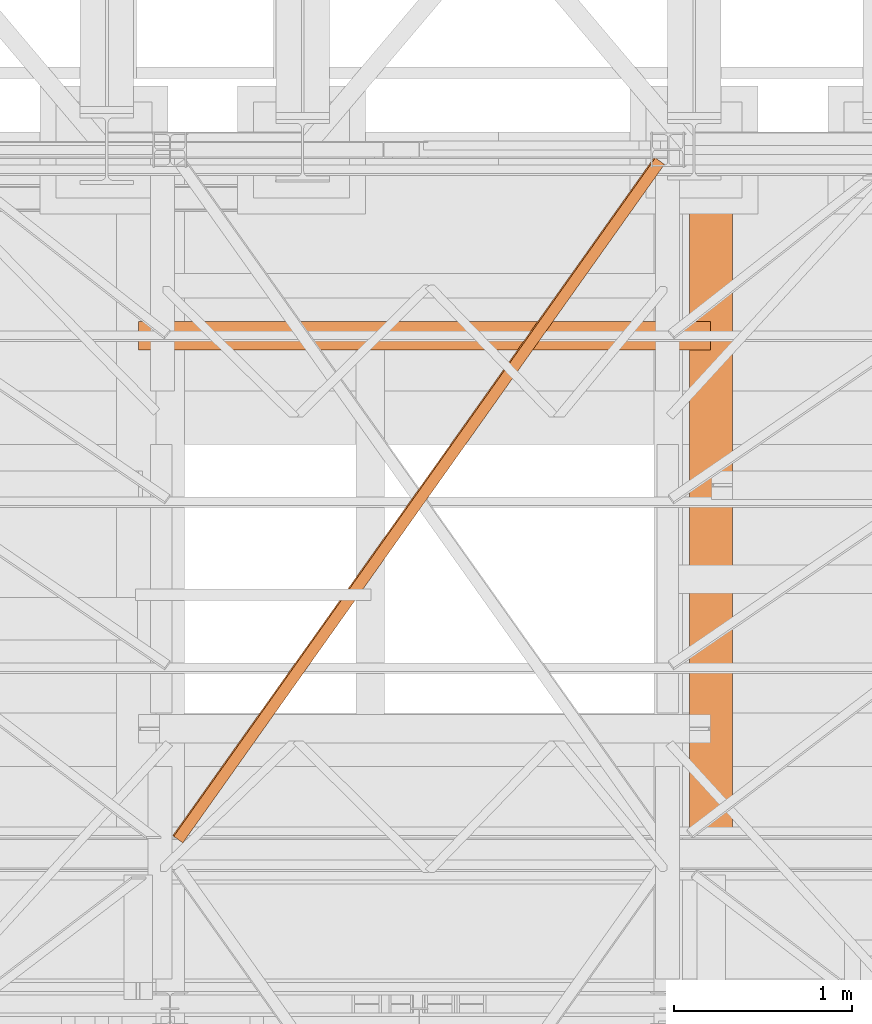
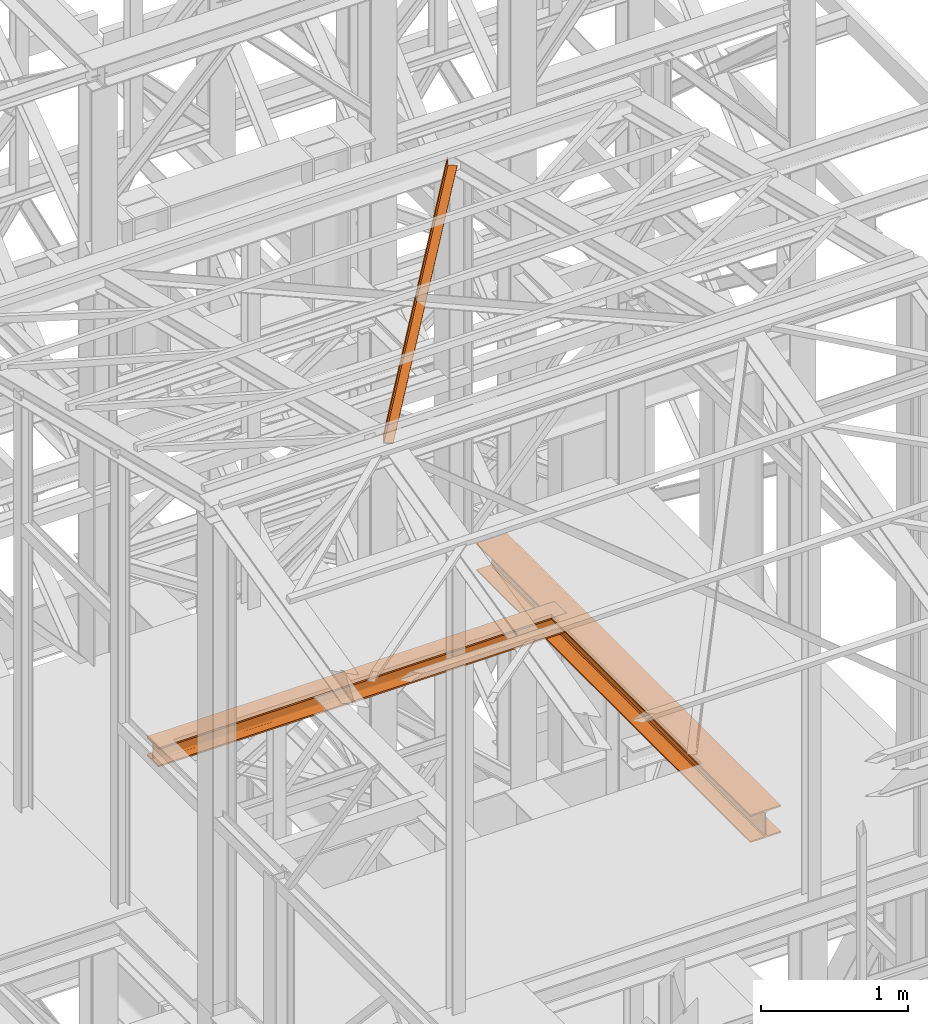
# One storey, part 69 of 208: 3 proxies.
"""IFC2X3 building model written with IfcOpenShell, lengths in millimetres."""

from ifc_helpers import new_model, entity, si_unit, converted_unit, frame, origin, origin_with_axes, place, context, subcontext, project, spatial, faceted_brep, element, save


model = new_model("IFC2X3")

# Units and contexts
model_context = context("Model", 3, precision=1e-05, world=origin())
plan_context = context("Plan", 3, precision=1e-05, world=origin())
body_context = subcontext(model_context, "Body", "Model", "MODEL_VIEW")
ifc_project = project(units=[si_unit("LENGTHUNIT", "METRE", prefix="MILLI"), converted_unit("PLANEANGLEUNIT", "DEGREE", entity("IfcPlaneAngleMeasure", 0.0174532925199433), si_unit("PLANEANGLEUNIT", "RADIAN"), dimensions=[0, 0, 0, 0, 0, 0, 0]), si_unit("AREAUNIT", "SQUARE_METRE"), si_unit("VOLUMEUNIT", "CUBIC_METRE")], contexts=[model_context, plan_context])

# Building, storey
building_placement = place(None, origin())
building = spatial("IfcBuilding", under=ifc_project, at=building_placement, CompositionType="COMPLEX")
storey_placement = place(building_placement, origin_with_axes())
storey = spatial("IfcBuildingStorey", under=building, at=storey_placement, Name="Geschoss", CompositionType="ELEMENT")

# Proxies
proxy_1_placement = place(storey_placement, frame((2372.004968677679, -18386.85030876191, 8324.990002086157), z_axis=(0.0, 0.0, 1.0), x_axis=(1.0, 0.0, 0.0)))
element("IfcBuildingElementProxy", 1, at=proxy_1_placement, inside=storey, Name="3D Element", context=body_context, shape_type="Brep", body=[
    faceted_brep([(3212.509999701976, 160.0099999999984, 0.01000000000021828), (3212.509999701976, 0.00999999999839929, 0.01000000000021828), (3212.509999701976, 0.00999999999839929, 13.01000000000022), (3212.509999701976, 61.0099999999984, 13.01000000000022), (3212.509999701976, 64.89227265598674, 13.52115656249407), (3212.509999701976, 68.50997812474452, 15.0196592323282), (3212.509999701976, 71.61660171780022, 17.40339828220203), (3212.509999701976, 74.00034076767406, 20.5100218752541), (3212.509999701976, 75.49884343750455, 24.12772734401187), (3212.509999701976, 76.0099999999984, 28.01000000000022), (3212.509999701976, 76.0099999999984, 132.0100000000002), (3212.509999701976, 75.49884343750455, 135.8922726559849), (3212.509999701976, 72.80847124273714, 141.0632899212706), (3212.509999701976, 71.61660171780022, 142.6166017177984), (3212.509999701976, 68.50997812474452, 145.0003407676722), (3212.509999701976, 64.89227265598674, 146.4988434375027), (3212.509999701976, 61.0099999999984, 147.0100000000002), (3212.509999701976, 0.00999999999839929, 147.0100000000002), (3212.509999701976, 0.00999999999839929, 160.0100000000002), (3212.509999701976, 160.0099999999984, 160.0100000000002), (3212.509999701976, 160.0099999999984, 147.0100000000002), (3212.509999701976, 99.0099999999984, 147.0100000000002), (3212.509999701976, 95.12772734401369, 146.4988434375027), (3212.509999701976, 91.51002187525592, 145.0003407676722), (3212.509999701976, 88.40339828220385, 142.6166017177984), (3212.509999701976, 86.01965923233001, 139.5099781247463), (3212.509999701976, 84.52115656249589, 135.8922726559849), (3212.509999701976, 84.0099999999984, 132.0100000000002), (3212.509999701976, 84.0099999999984, 28.01000000000022), (3212.509999701976, 84.74420336541152, 23.37476080785382), (3212.509999701976, 86.87476363144378, 19.19323607455408), (3212.509999701976, 90.1932360745559, 15.87476363144197), (3212.509999701976, 94.37476080785564, 13.7442033654097), (3212.509999701976, 99.0099999999984, 13.01000000000022), (3212.509999701976, 160.0099999999984, 13.01000000000022), (3212.509999701976, 0.00999999999839929, 0.01000000000021828), (3212.509999701976, 160.0099999999984, 0.01000000000021828), (0.01000000000021828, 160.0100000000057, 0.01000000000021828), (0.01000000000021828, 0.01000000000567525, 0.01000000000021828), (3212.509999701976, 0.00999999999839929, 13.01000000000022), (3212.509999701976, 0.00999999999839929, 0.01000000000021828), (0.01000000000021828, 0.01000000000567525, 0.01000000000021828), (0.01000000000021828, 0.01000000000567525, 13.01000000000022), (3212.509999701976, 61.0099999999984, 13.01000000000022), (3212.509999701976, 0.00999999999839929, 13.01000000000022), (0.01000000000021828, 0.01000000000567525, 13.01000000000022), (0.01000000000021828, 61.01000000000568, 13.01000000000022), (3212.509999701976, 64.89227265598674, 13.52115656249407), (3212.509999701976, 61.0099999999984, 13.01000000000022), (0.01000000000021828, 61.01000000000568, 13.01000000000022), (0.01000000000021828, 64.89227265599402, 13.52115656249407), (3212.509999701976, 68.50997812474452, 15.0196592323282), (3212.509999701976, 64.89227265598674, 13.52115656249407), (0.01000000000021828, 64.89227265599402, 13.52115656249407), (0.01000000000021828, 68.5099781247518, 15.0196592323282), (3212.509999701976, 71.61660171780022, 17.40339828220203), (3212.509999701976, 68.50997812474452, 15.0196592323282), (0.01000000000021828, 68.5099781247518, 15.0196592323282), (0.01000000000021828, 71.6166017178075, 17.40339828220203), (3212.509999701976, 74.00034076767406, 20.5100218752541), (3212.509999701976, 71.61660171780022, 17.40339828220203), (0.01000000000021828, 71.6166017178075, 17.40339828220203), (0.01000000000021828, 74.00034076768134, 20.5100218752541), (3212.509999701976, 75.49884343750455, 24.12772734401187), (3212.509999701976, 74.00034076767406, 20.5100218752541), (0.01000000000021828, 74.00034076768134, 20.5100218752541), (0.01000000000021828, 75.49884343751182, 24.12772734401187), (3212.509999701976, 76.0099999999984, 28.01000000000022), (3212.509999701976, 75.49884343750455, 24.12772734401187), (0.01000000000021828, 75.49884343751182, 24.12772734401187), (0.01000000000021828, 76.01000000000568, 28.01000000000022), (3212.509999701976, 76.0099999999984, 132.0100000000002), (3212.509999701976, 76.0099999999984, 28.01000000000022), (0.01000000000021828, 76.01000000000568, 28.01000000000022), (0.01000000000021828, 76.01000000000568, 132.0100000000002), (3212.509999701976, 75.49884343750455, 135.8922726559849), (3212.509999701976, 76.0099999999984, 132.0100000000002), (0.01000000000021828, 76.01000000000568, 132.0100000000002), (0.01000000000021828, 75.49884343751182, 135.8922726559849), (3212.509999701976, 72.80847124273714, 141.0632899212706), (3212.509999701976, 75.49884343750455, 135.8922726559849), (0.01000000000021828, 75.49884343751182, 135.8922726559849), (0.01000000000021828, 72.80847124274442, 141.0632899212706), (3212.509999701976, 71.61660171780022, 142.6166017177984), (3212.509999701976, 72.80847124273714, 141.0632899212706), (0.01000000000021828, 72.80847124274442, 141.0632899212706), (0.01000000000021828, 71.6166017178075, 142.6166017177984), (3212.509999701976, 68.50997812474452, 145.0003407676722), (3212.509999701976, 71.61660171780022, 142.6166017177984), (0.01000000000021828, 71.6166017178075, 142.6166017177984), (0.01000000000021828, 68.5099781247518, 145.0003407676722), (3212.509999701976, 64.89227265598674, 146.4988434375027), (3212.509999701976, 68.50997812474452, 145.0003407676722), (0.01000000000021828, 68.5099781247518, 145.0003407676722), (0.01000000000021828, 64.89227265599402, 146.4988434375027), (3212.509999701976, 61.0099999999984, 147.0100000000002), (3212.509999701976, 64.89227265598674, 146.4988434375027), (0.01000000000021828, 64.89227265599402, 146.4988434375027), (0.01000000000021828, 61.01000000000568, 147.0100000000002), (3212.509999701976, 0.00999999999839929, 147.0100000000002), (3212.509999701976, 61.0099999999984, 147.0100000000002), (0.01000000000021828, 61.01000000000568, 147.0100000000002), (0.01000000000021828, 0.01000000000567525, 147.0100000000002), (3212.509999701976, 0.00999999999839929, 160.0100000000002), (3212.509999701976, 0.00999999999839929, 147.0100000000002), (0.01000000000021828, 0.01000000000567525, 147.0100000000002), (0.01000000000021828, 0.01000000000567525, 160.0100000000002), (3212.509999701976, 160.0099999999984, 160.0100000000002), (3212.509999701976, 0.00999999999839929, 160.0100000000002), (0.01000000000021828, 0.01000000000567525, 160.0100000000002), (0.01000000000021828, 160.0100000000057, 160.0100000000002), (3212.509999701976, 160.0099999999984, 147.0100000000002), (3212.509999701976, 160.0099999999984, 160.0100000000002), (0.01000000000021828, 160.0100000000057, 160.0100000000002), (0.01000000000021828, 160.0100000000057, 147.0100000000002), (3212.509999701976, 99.0099999999984, 147.0100000000002), (3212.509999701976, 160.0099999999984, 147.0100000000002), (0.01000000000021828, 160.0100000000057, 147.0100000000002), (0.01000000000021828, 99.01000000000568, 147.0100000000002), (3212.509999701976, 95.12772734401369, 146.4988434375027), (3212.509999701976, 99.0099999999984, 147.0100000000002), (0.01000000000021828, 99.01000000000568, 147.0100000000002), (0.01000000000021828, 95.12772734402097, 146.4988434375027), (3212.509999701976, 91.51002187525592, 145.0003407676722), (3212.509999701976, 95.12772734401369, 146.4988434375027), (0.01000000000021828, 95.12772734402097, 146.4988434375027), (0.01000000000021828, 91.51002187526319, 145.0003407676722), (3212.509999701976, 88.40339828220385, 142.6166017177984), (3212.509999701976, 91.51002187525592, 145.0003407676722), (0.01000000000021828, 91.51002187526319, 145.0003407676722), (0.01000000000021828, 88.40339828221113, 142.6166017177984), (3212.509999701976, 86.01965923233001, 139.5099781247463), (3212.509999701976, 88.40339828220385, 142.6166017177984), (0.01000000000021828, 88.40339828221113, 142.6166017177984), (0.01000000000021828, 86.01965923233729, 139.5099781247463), (3212.509999701976, 84.52115656249589, 135.8922726559849), (3212.509999701976, 86.01965923233001, 139.5099781247463), (0.01000000000021828, 86.01965923233729, 139.5099781247463), (0.01000000000021828, 84.52115656250317, 135.8922726559849), (3212.509999701976, 84.0099999999984, 132.0100000000002), (3212.509999701976, 84.52115656249589, 135.8922726559849), (0.01000000000021828, 84.52115656250317, 135.8922726559849), (0.01000000000021828, 84.01000000000568, 132.0100000000002), (3212.509999701976, 84.0099999999984, 28.01000000000022), (3212.509999701976, 84.0099999999984, 132.0100000000002), (0.01000000000021828, 84.01000000000568, 132.0100000000002), (0.01000000000021828, 84.01000000000568, 28.01000000000022), (3212.509999701976, 84.74420336541152, 23.37476080785382), (3212.509999701976, 84.0099999999984, 28.01000000000022), (0.01000000000021828, 84.01000000000568, 28.01000000000022), (0.01000000000021828, 84.7442033654188, 23.37476080785382), (3212.509999701976, 86.87476363144378, 19.19323607455408), (3212.509999701976, 84.74420336541152, 23.37476080785382), (0.01000000000021828, 84.7442033654188, 23.37476080785382), (0.01000000000021828, 86.87476363145106, 19.19323607455408), (3212.509999701976, 90.1932360745559, 15.87476363144197), (3212.509999701976, 86.87476363144378, 19.19323607455408), (0.01000000000021828, 86.87476363145106, 19.19323607455408), (0.01000000000021828, 90.19323607456317, 15.87476363144197), (3212.509999701976, 94.37476080785564, 13.7442033654097), (3212.509999701976, 90.1932360745559, 15.87476363144197), (0.01000000000021828, 90.19323607456317, 15.87476363144197), (0.01000000000021828, 94.37476080786291, 13.7442033654097), (3212.509999701976, 99.0099999999984, 13.01000000000022), (3212.509999701976, 94.37476080785564, 13.7442033654097), (0.01000000000021828, 94.37476080786291, 13.7442033654097), (0.01000000000021828, 99.01000000000568, 13.01000000000022), (3212.509999701976, 160.0099999999984, 13.01000000000022), (3212.509999701976, 99.0099999999984, 13.01000000000022), (0.01000000000021828, 99.01000000000568, 13.01000000000022), (0.01000000000021828, 160.0100000000057, 13.01000000000022), (3212.509999701976, 160.0099999999984, 0.01000000000021828), (3212.509999701976, 160.0099999999984, 13.01000000000022), (0.01000000000021828, 160.0100000000057, 13.01000000000022), (0.01000000000021828, 160.0100000000057, 0.01000000000021828), (0.01000000000021828, 160.0100000000057, 0.01000000000021828), (0.01000000000021828, 160.0100000000057, 13.01000000000022), (0.01000000000021828, 99.01000000000568, 13.01000000000022), (0.01000000000021828, 94.37476080786291, 13.7442033654097), (0.01000000000021828, 90.19323607456317, 15.87476363144197), (0.01000000000021828, 86.87476363145106, 19.19323607455408), (0.01000000000021828, 84.7442033654188, 23.37476080785382), (0.01000000000021828, 84.01000000000568, 28.01000000000022), (0.01000000000021828, 84.01000000000568, 132.0100000000002), (0.01000000000021828, 84.52115656250317, 135.8922726559849), (0.01000000000021828, 86.01965923233729, 139.5099781247463), (0.01000000000021828, 88.40339828221113, 142.6166017177984), (0.01000000000021828, 91.51002187526319, 145.0003407676722), (0.01000000000021828, 95.12772734402097, 146.4988434375027), (0.01000000000021828, 99.01000000000568, 147.0100000000002), (0.01000000000021828, 160.0100000000057, 147.0100000000002), (0.01000000000021828, 160.0100000000057, 160.0100000000002), (0.01000000000021828, 0.01000000000567525, 160.0100000000002), (0.01000000000021828, 0.01000000000567525, 147.0100000000002), (0.01000000000021828, 61.01000000000568, 147.0100000000002), (0.01000000000021828, 64.89227265599402, 146.4988434375027), (0.01000000000021828, 68.5099781247518, 145.0003407676722), (0.01000000000021828, 71.6166017178075, 142.6166017177984), (0.01000000000021828, 72.80847124274442, 141.0632899212706), (0.01000000000021828, 75.49884343751182, 135.8922726559849), (0.01000000000021828, 76.01000000000568, 132.0100000000002), (0.01000000000021828, 76.01000000000568, 28.01000000000022), (0.01000000000021828, 75.49884343751182, 24.12772734401187), (0.01000000000021828, 74.00034076768134, 20.5100218752541), (0.01000000000021828, 71.6166017178075, 17.40339828220203), (0.01000000000021828, 68.5099781247518, 15.0196592323282), (0.01000000000021828, 64.89227265599402, 13.52115656249407), (0.01000000000021828, 61.01000000000568, 13.01000000000022), (0.01000000000021828, 0.01000000000567525, 13.01000000000022), (0.01000000000021828, 0.01000000000567525, 0.01000000000021828)], [[[0, 1, 2, 3, 4, 5, 6, 7, 8, 9, 10, 11, 12, 13, 14, 15, 16, 17, 18, 19, 20, 21, 22, 23, 24, 25, 26, 27, 28, 29, 30, 31, 32, 33, 34]], [[35, 36, 37, 38]], [[39, 40, 41, 42]], [[43, 44, 45, 46]], [[47, 48, 49, 50]], [[51, 52, 53, 54]], [[55, 56, 57, 58]], [[59, 60, 61, 62]], [[63, 64, 65, 66]], [[67, 68, 69, 70]], [[71, 72, 73, 74]], [[75, 76, 77, 78]], [[79, 80, 81, 82]], [[83, 84, 85, 86]], [[87, 88, 89, 90]], [[91, 92, 93, 94]], [[95, 96, 97, 98]], [[99, 100, 101, 102]], [[103, 104, 105, 106]], [[107, 108, 109, 110]], [[111, 112, 113, 114]], [[115, 116, 117, 118]], [[119, 120, 121, 122]], [[123, 124, 125, 126]], [[127, 128, 129, 130]], [[131, 132, 133, 134]], [[135, 136, 137, 138]], [[139, 140, 141, 142]], [[143, 144, 145, 146]], [[147, 148, 149, 150]], [[151, 152, 153, 154]], [[155, 156, 157, 158]], [[159, 160, 161, 162]], [[163, 164, 165, 166]], [[167, 168, 169, 170]], [[171, 172, 173, 174]], [[175, 176, 177, 178, 179, 180, 181, 182, 183, 184, 185, 186, 187, 188, 189, 190, 191, 192, 193, 194, 195, 196, 197, 198, 199, 200, 201, 202, 203, 204, 205, 206, 207, 208, 209]]], orient=[[False], [False], [False], [False], [False], [False], [False], [False], [False], [False], [False], [False], [False], [False], [False], [False], [False], [False], [False], [False], [False], [False], [False], [False], [False], [False], [False], [False], [False], [False], [False], [False], [False], [False], [False], [False], [False]]),
])
proxy_2_placement = place(storey_placement, frame((5468.254963760295, -21097.57438554952, 8254.989997913835), z_axis=(0.0, 0.0, 1.0), x_axis=(1.0, 0.0, 0.0)))
element("IfcBuildingElementProxy", 2, at=proxy_2_placement, inside=storey, context=body_context, shape_type="Brep", body=[
    faceted_brep([(240.0100095367434, 3735.009995231631, 230.0100041723217), (240.0100095367416, 0.01000000000203727, 230.0100041723217), (0.01000000000021828, 0.01000000000203727, 230.0100041723217), (0.01000000000112777, 3735.009995231631, 230.0100041723217), (0.01000000000112777, 3735.009995231631, 230.0100041723217), (0.01000000000021828, 0.01000000000203727, 230.0100041723217), (0.009999999999308784, 0.01000000000203727, 218.0100022053684), (0.01000000000112777, 3735.009995231631, 218.0100022053684), (0.01000000000112777, 3735.009995231631, 218.0100022053684), (0.009999999999308784, 0.01000000000203727, 218.0100022053684), (95.26000303983619, 0.01000000000203727, 218.0100022053684), (95.26000303983801, 3735.009995231631, 218.0100022053684), (95.26000303983801, 3735.009995231631, 218.0100022053684), (95.26000303983619, 0.01000000000203727, 218.0100022053684), (106.1284490099542, 0.01000000000203727, 215.8347008919682), (106.1284490099561, 3735.009995231634, 215.8347008919682), (106.1284490099561, 3735.009995231634, 215.8347008919682), (106.1284490099542, 0.01000000000203727, 215.8347008919682), (114.0846986493461, 0.01000000000203727, 207.8784493899311), (114.084698649348, 3735.009995231631, 207.8784493899311), (114.084698649348, 3735.009995231631, 207.8784493899311), (114.0846986493461, 0.01000000000203727, 207.8784493899311), (116.2600046193593, 0.01000000000203727, 197.0100043511357), (116.2600046193602, 3735.009995231634, 197.0100043511357), (116.2600046193602, 3735.009995231634, 197.0100043511357), (116.2600046193593, 0.01000000000203727, 197.0100043511357), (116.2600046193593, 0.01000000000203727, 33.00999982118628), (116.2600046193602, 3735.009995231634, 33.00999982118628), (116.2600046193602, 3735.009995231634, 33.00999982118628), (116.2600046193593, 0.01000000000203727, 33.00999982118628), (114.0846986493461, 0.01000000000203727, 22.14155478239081), (114.084698649348, 3735.009995231634, 22.14155478239081), (114.084698649348, 3735.009995231634, 22.14155478239081), (114.0846986493461, 0.01000000000203727, 22.14155478239081), (106.1284490099542, 0.01000000000203727, 14.18530328035376), (106.1284490099561, 3735.009995231634, 14.18530328035376), (106.1284490099561, 3735.009995231634, 14.18530328035376), (106.1284490099542, 0.01000000000203727, 14.18530328035376), (95.26000303983619, 0.01000000000203727, 12.0100019669535), (95.26000303983801, 3735.009995231631, 12.0100019669535), (95.26000303983801, 3735.009995231631, 12.0100019669535), (95.26000303983619, 0.01000000000203727, 12.0100019669535), (0.01000000000021828, 0.01000000000203727, 12.0100019669535), (0.01000000000112777, 3735.009995231634, 12.0100019669535), (0.01000000000112777, 3735.009995231634, 12.0100019669535), (0.01000000000021828, 0.01000000000203727, 12.0100019669535), (0.009999999999308784, 0.01000000000203727, 0.01000000000021828), (0.01000000000112777, 3735.009995231631, 0.01000000000021828), (0.01000000000112777, 3735.009995231631, 0.01000000000021828), (0.009999999999308784, 0.01000000000203727, 0.01000000000021828), (240.0100095367416, 0.01000000000203727, 0.00999999999839929), (240.0100095367434, 3735.009995231631, 0.01000000000021828), (240.0100095367434, 3735.009995231631, 0.01000000000021828), (240.0100095367416, 0.01000000000203727, 0.00999999999839929), (240.0100095367416, 0.01000000000203727, 12.0100019669535), (240.0100095367434, 3735.009995231631, 12.0100019669535), (240.0100095367434, 3735.009995231631, 12.0100019669535), (240.0100095367416, 0.01000000000203727, 12.0100019669535), (144.7600064969047, 0.01000000000203727, 12.0100019669535), (144.7600064969065, 3735.009995231634, 12.0100019669535), (144.7600064969065, 3735.009995231634, 12.0100019669535), (144.7600064969047, 0.01000000000203727, 12.0100019669535), (133.8915605267866, 0.01000000000203727, 14.18530328035376), (133.8915605267885, 3735.009995231634, 14.18530328035376), (133.8915605267885, 3735.009995231634, 14.18530328035376), (133.8915605267866, 0.01000000000203727, 14.18530328035376), (125.9353108873947, 0.01000000000203727, 22.14155478239081), (125.9353108873966, 3735.009995231634, 22.14155478239081), (125.9353108873966, 3735.009995231634, 22.14155478239081), (125.9353108873947, 0.01000000000203727, 22.14155478239081), (123.7600049173816, 0.01000000000203727, 33.00999982118628), (123.7600049173834, 3735.009995231634, 33.00999982118628), (123.7600049173834, 3735.009995231634, 33.00999982118628), (123.7600049173816, 0.01000000000203727, 33.00999982118628), (123.7600049173816, 0.01000000000203727, 197.0100043511357), (123.7600049173834, 3735.009995231634, 197.0100043511357), (123.7600049173834, 3735.009995231634, 197.0100043511357), (123.7600049173816, 0.01000000000203727, 197.0100043511357), (125.9353108873947, 0.01000000000203727, 207.8784493899311), (125.9353108873966, 3735.009995231631, 207.8784493899311), (125.9353108873966, 3735.009995231631, 207.8784493899311), (125.9353108873947, 0.01000000000203727, 207.8784493899311), (133.8915605267866, 0.01000000000203727, 215.83470089197), (133.8915605267885, 3735.009995231631, 215.8347008919682), (133.8915605267885, 3735.009995231631, 215.8347008919682), (133.8915605267866, 0.01000000000203727, 215.83470089197), (144.7600064969047, 0.01000000000203727, 218.0100022053684), (144.7600064969065, 3735.009995231631, 218.0100022053684), (144.7600064969065, 3735.009995231631, 218.0100022053684), (144.7600064969047, 0.01000000000203727, 218.0100022053684), (240.0100095367416, 0.01000000000203727, 218.0100022053684), (240.0100095367434, 3735.009995231631, 218.0100022053684), (240.0100095367434, 3735.009995231631, 218.0100022053684), (240.0100095367416, 0.01000000000203727, 218.0100022053684), (240.0100095367416, 0.01000000000203727, 230.0100041723217), (240.0100095367434, 3735.009995231631, 230.0100041723217), (0.01000000000112777, 3735.009995231631, 230.0100041723217), (0.01000000000112777, 3735.009995231631, 218.0100022053684), (95.26000303983801, 3735.009995231631, 218.0100022053684), (106.1284490099561, 3735.009995231634, 215.8347008919682), (114.084698649348, 3735.009995231631, 207.8784493899311), (116.2600046193602, 3735.009995231634, 197.0100043511357), (116.2600046193602, 3735.009995231634, 33.00999982118628), (114.084698649348, 3735.009995231634, 22.14155478239081), (106.1284490099561, 3735.009995231634, 14.18530328035376), (95.26000303983801, 3735.009995231631, 12.0100019669535), (0.01000000000112777, 3735.009995231634, 12.0100019669535), (0.01000000000112777, 3735.009995231631, 0.01000000000021828), (240.0100095367434, 3735.009995231631, 0.01000000000021828), (240.0100095367434, 3735.009995231631, 12.0100019669535), (144.7600064969065, 3735.009995231634, 12.0100019669535), (133.8915605267885, 3735.009995231634, 14.18530328035376), (125.9353108873966, 3735.009995231634, 22.14155478239081), (123.7600049173834, 3735.009995231634, 33.00999982118628), (123.7600049173834, 3735.009995231634, 197.0100043511357), (125.9353108873966, 3735.009995231631, 207.8784493899311), (133.8915605267885, 3735.009995231631, 215.8347008919682), (144.7600064969065, 3735.009995231631, 218.0100022053684), (240.0100095367434, 3735.009995231631, 218.0100022053684), (240.0100095367434, 3735.009995231631, 230.0100041723217), (240.0100095367416, 0.01000000000203727, 230.0100041723217), (240.0100095367416, 0.01000000000203727, 218.0100022053684), (144.7600064969047, 0.01000000000203727, 218.0100022053684), (133.8915605267866, 0.01000000000203727, 215.83470089197), (125.9353108873947, 0.01000000000203727, 207.8784493899311), (123.7600049173816, 0.01000000000203727, 197.0100043511357), (123.7600049173816, 0.01000000000203727, 33.00999982118628), (125.9353108873947, 0.01000000000203727, 22.14155478239081), (133.8915605267866, 0.01000000000203727, 14.18530328035376), (144.7600064969047, 0.01000000000203727, 12.0100019669535), (240.0100095367416, 0.01000000000203727, 12.0100019669535), (240.0100095367416, 0.01000000000203727, 0.00999999999839929), (0.009999999999308784, 0.01000000000203727, 0.01000000000021828), (0.01000000000021828, 0.01000000000203727, 12.0100019669535), (95.26000303983619, 0.01000000000203727, 12.0100019669535), (106.1284490099542, 0.01000000000203727, 14.18530328035376), (114.0846986493461, 0.01000000000203727, 22.14155478239081), (116.2600046193593, 0.01000000000203727, 33.00999982118628), (116.2600046193593, 0.01000000000203727, 197.0100043511357), (114.0846986493461, 0.01000000000203727, 207.8784493899311), (106.1284490099542, 0.01000000000203727, 215.8347008919682), (95.26000303983619, 0.01000000000203727, 218.0100022053684), (0.009999999999308784, 0.01000000000203727, 218.0100022053684), (0.01000000000021828, 0.01000000000203727, 230.0100041723217)], [[[0, 1, 2, 3]], [[4, 5, 6, 7]], [[8, 9, 10, 11]], [[12, 13, 14, 15]], [[16, 17, 18, 19]], [[20, 21, 22, 23]], [[24, 25, 26, 27]], [[28, 29, 30, 31]], [[32, 33, 34, 35]], [[36, 37, 38, 39]], [[40, 41, 42, 43]], [[44, 45, 46, 47]], [[48, 49, 50, 51]], [[52, 53, 54, 55]], [[56, 57, 58, 59]], [[60, 61, 62, 63]], [[64, 65, 66, 67]], [[68, 69, 70, 71]], [[72, 73, 74, 75]], [[76, 77, 78, 79]], [[80, 81, 82, 83]], [[84, 85, 86, 87]], [[88, 89, 90, 91]], [[92, 93, 94, 95]], [[96, 97, 98, 99, 100, 101, 102, 103, 104, 105, 106, 107, 108, 109, 110, 111, 112, 113, 114, 115, 116, 117, 118, 119]], [[120, 121, 122, 123, 124, 125, 126, 127, 128, 129, 130, 131, 132, 133, 134, 135, 136, 137, 138, 139, 140, 141, 142, 143]]], orient=[[False], [False], [False], [False], [False], [False], [False], [False], [False], [False], [False], [False], [False], [False], [False], [False], [False], [False], [False], [False], [False], [False], [False], [False], [False], [False]]),
])
proxy_3_placement = place(storey_placement, frame((2562.87849289545, -21157.48912214136, 11662.12296240696), z_axis=(0.0, 0.0, 1.0), x_axis=(1.0, 0.0, 0.0)))
element("IfcBuildingElementProxy", 3, at=proxy_3_placement, inside=storey, context=body_context, shape_type="Brep", body=[
    faceted_brep([(5.7182461291859, 36.47556649721446, 1017.606612844891), (2712.523557275226, 3849.652846714471, 71.42860080890387), (2712.524383413974, 3849.652260329276, 7.151908000914773), (5.71907226793337, 36.47498011201969, 953.3299200369001), (0.01000000000021828, 40.52722371478376, 1017.606559600419), (2706.815311146042, 3853.70450393204, 71.42854756443194), (2712.523557275226, 3849.652846714471, 71.42860080890387), (5.7182461291859, 36.47556649721446, 1017.606612844891), (0.01091793194336788, 40.52657217567685, 946.1880120359856), (2706.816229077984, 3853.703852392933, 0.01000000000021828), (2706.815311146042, 3853.70450393204, 71.42854756443194), (0.01000000000021828, 40.52722371478376, 1017.606559600419), (57.09337922378745, 0.00999999999839929, 946.188544480714), (2763.898690369828, 3813.187280217251, 0.01053244472677761), (2706.816229077984, 3853.703852392933, 0.01000000000021828), (0.01091793194336788, 40.52657217567685, 946.1880120359856), (57.0932874305945, 0.01006515391054563, 953.3303992371548), (2763.89859857663, 3813.18734537116, 7.152387201171223), (2763.898690369828, 3813.187280217251, 0.01053244472677761), (57.09337922378745, 0.00999999999839929, 946.188544480714), (5.71907226793337, 36.47498011201969, 953.3299200369001), (2712.524383413974, 3849.652260329276, 7.151908000914773), (2763.89859857663, 3813.18734537116, 7.152387201171223), (57.0932874305945, 0.01006515391054563, 953.3303992371548), (2712.523557275226, 3849.652846714471, 71.42860080890387), (2706.815311146042, 3853.70450393204, 71.42854756443194), (2706.816229077984, 3853.703852392933, 0.01000000000021828), (2763.898690369828, 3813.187280217251, 0.01053244472677761), (2763.89859857663, 3813.18734537116, 7.152387201171223), (2712.524383413974, 3849.652260329276, 7.151908000914773), (5.71907226793337, 36.47498011201969, 953.3299200369001), (57.0932874305945, 0.01006515391054563, 953.3303992371548), (57.09337922378745, 0.00999999999839929, 946.188544480714), (0.01091793194336788, 40.52657217567685, 946.1880120359856), (0.01000000000021828, 40.52722371478376, 1017.606559600419), (5.7182461291859, 36.47556649721446, 1017.606612844891)], [[[0, 1, 2, 3]], [[4, 5, 6, 7]], [[8, 9, 10, 11]], [[12, 13, 14, 15]], [[16, 17, 18, 19]], [[20, 21, 22, 23]], [[24, 25, 26, 27, 28, 29]], [[30, 31, 32, 33, 34, 35]]], orient=[[False], [False], [False], [False], [False], [False], [False], [False]]),
])

save(model, "model.ifc")
